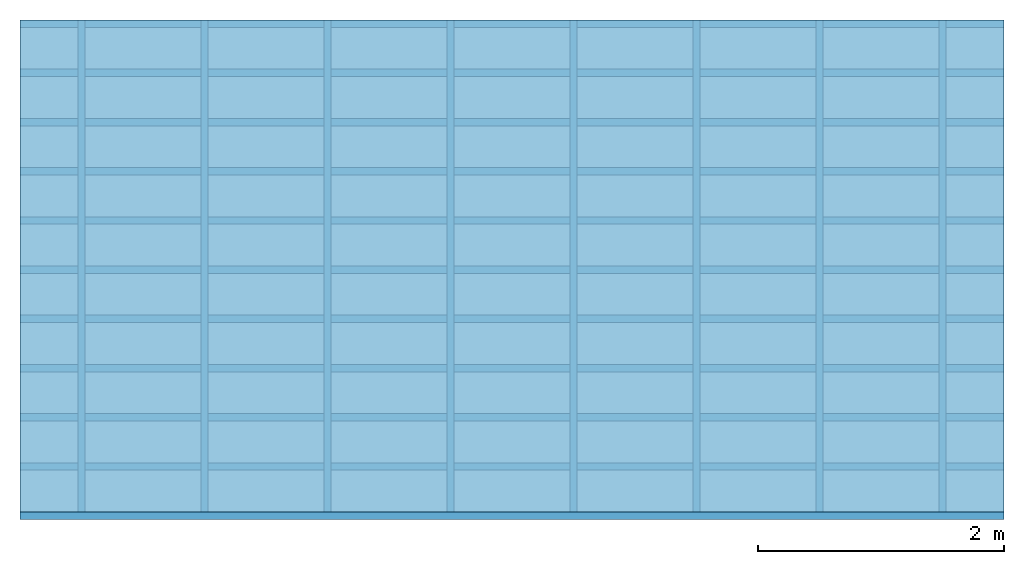
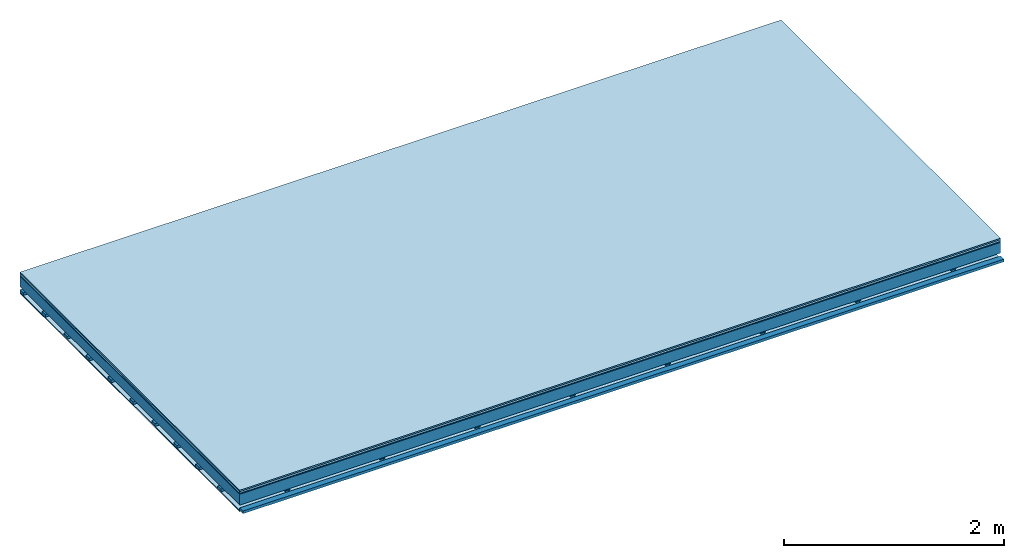
# One storey: 5 plates, 3 members, 1 element without a shape of its own.
"""IFC4 building model written with IfcOpenShell, lengths in metres."""

import ifcopenshell
import ifcopenshell.guid

model = None  # the IFC model being written
_history = None  # IfcOwnerHistory: only IFC2X3 demands one
_inside = {}  # id of a spatial element -> (the spatial element, [elements in it])
_under = {}  # id of a project, library or spatial element -> (it, [spatial elements below it])
_declared = {}  # id of a project -> (the project, [libraries it declares])
_typed = {}  # id of a type object -> (the type object, [elements of that type])
_made_of = {}  # id of a material, layer set ... -> (it, [elements and type objects made of it])


def new_model(schema):
    """Start an empty IFC model of exactly this schema.

    Asked for "IFC4X3", IfcOpenShell would pick the latest addendum, in which some entities
    have other attributes; the version numbers below select the first issue.
    IFC2X3 requires an IfcOwnerHistory on every rooted entity: one is made here for all.
    """
    global model, _history
    if schema == "IFC4X3":
        model = ifcopenshell.file(schema_version=(4, 3, 0, 0))
    else:
        model = ifcopenshell.file(schema=schema)
    _inside.clear()
    _under.clear()
    _declared.clear()
    _typed.clear()
    _made_of.clear()
    _history = None
    if model.schema == "IFC2X3":
        org = make("IfcOrganization", Name="unknown")
        user = make(
            "IfcPersonAndOrganization",
            ThePerson=make("IfcPerson", FamilyName="unknown"),
            TheOrganization=org,
        )
        app = make(
            "IfcApplication",
            ApplicationDeveloper=org,
            Version="unknown",
            ApplicationFullName="unknown",
            ApplicationIdentifier="unknown",
        )
        _history = make(
            "IfcOwnerHistory",
            OwningUser=user,
            OwningApplication=app,
            ChangeAction="ADDED",
            CreationDate=0,
        )
    return model


def make(cls, **values):
    """One entity of the class cls with the attributes given. An attribute that is None is left unset."""
    return model.create_entity(
        cls, **{name: value for name, value in values.items() if value is not None}
    )


def rooted(cls, **values):
    """An entity with a GlobalId (a new one), such as an element, a storey or a relation."""
    return make(cls, GlobalId=ifcopenshell.guid.new(), OwnerHistory=_history, **values)


def si_unit(unit_type, name, prefix=None):
    """IfcSIUnit, for example si_unit("LENGTHUNIT", "METRE", prefix="MILLI")."""
    return make("IfcSIUnit", UnitType=unit_type, Prefix=prefix, Name=name)


def derived_unit(unit_type, elements):
    """IfcDerivedUnit: a product of units, each with its exponent."""
    return make(
        "IfcDerivedUnit",
        Elements=[
            make("IfcDerivedUnitElement", Unit=unit, Exponent=power)
            for unit, power in elements
        ],
        UnitType=unit_type,
    )


def assignment(units):
    """IfcUnitAssignment: the units of a project."""
    return None if units is None else make("IfcUnitAssignment", Units=units)


def point(xyz):
    """IfcCartesianPoint."""
    return None if xyz is None else make("IfcCartesianPoint", Coordinates=xyz)


def direction(xyz):
    """IfcDirection."""
    return None if xyz is None else make("IfcDirection", DirectionRatios=xyz)


def frame(location, z_axis=None, x_axis=None):
    """IfcAxis2Placement3D, a coordinate frame: its origin and axes. An axis left out is left unset."""
    return make(
        "IfcAxis2Placement3D",
        Location=point(location),
        Axis=direction(z_axis),
        RefDirection=direction(x_axis),
    )


def frame_2d(location, x_axis=None):
    """IfcAxis2Placement2D, a coordinate frame in the plane: its origin and x axis."""
    return make(
        "IfcAxis2Placement2D", Location=point(location), RefDirection=direction(x_axis)
    )


def origin():
    """The frame at (0, 0, 0) with its axes left unset."""
    return frame((0.0, 0.0, 0.0))


def origin_with_axes():
    """The frame at (0, 0, 0) with the z axis (0, 0, 1) and the x axis (1, 0, 0) written out."""
    return frame((0.0, 0.0, 0.0), z_axis=(0.0, 0.0, 1.0), x_axis=(1.0, 0.0, 0.0))


def place(relative_to, where):
    """IfcLocalPlacement: puts the frame where relative to a parent placement (None: the world)."""
    return make(
        "IfcLocalPlacement", PlacementRelTo=relative_to, RelativePlacement=where
    )


def context(
    kind, dimensions, precision=None, world=None, true_north=None, identifier=None
):
    """IfcGeometricRepresentationContext, for example the 3D "Model" context."""
    return make(
        "IfcGeometricRepresentationContext",
        ContextIdentifier=identifier,
        ContextType=kind,
        CoordinateSpaceDimension=dimensions,
        Precision=precision,
        WorldCoordinateSystem=world,
        TrueNorth=true_north,
    )


def project(units=None, contexts=None):
    """IfcProject with its units and contexts."""
    return rooted(
        "IfcProject",
        Name="project",
        RepresentationContexts=contexts,
        UnitsInContext=assignment(units),
    )


def spatial(cls, under=None, at=None, **own):
    """A site, building, storey or space (cls), placed at a placement, below another one or the project."""
    s = rooted(cls, ObjectPlacement=at, **own)
    if under is not None:
        _under.setdefault(under.id(), (under, []))[1].append(s)
    return s


def polyline(points):
    """IfcPolyline through the points."""
    return make("IfcPolyline", Points=[point(p) for p in points])


def profile(cls, at=None, kind="AREA", **sizes):
    """A parametric profile (cls). Its sizes go by their IFC names, for example OverallWidth=200.0."""
    return make(cls, ProfileType=kind, Position=at, **sizes)


def rectangle(**sizes):
    """IfcRectangleProfileDef."""
    return profile("IfcRectangleProfileDef", **sizes)


def outline(outer, holes=None, kind="AREA"):
    """IfcArbitraryClosedProfileDef: a profile drawn as a closed curve; with holes, ...WithVoids."""
    if holes is None:
        return make("IfcArbitraryClosedProfileDef", ProfileType=kind, OuterCurve=outer)
    return make(
        "IfcArbitraryProfileDefWithVoids",
        ProfileType=kind,
        OuterCurve=outer,
        InnerCurves=holes,
    )


def extrude(swept, where, along, depth):
    """IfcExtrudedAreaSolid: the profile swept, set in the frame where, extruded along a direction by depth."""
    return make(
        "IfcExtrudedAreaSolid",
        SweptArea=swept,
        Position=where,
        ExtrudedDirection=direction(along),
        Depth=depth,
    )


def shape(context_of_items, identifier, shape_type, items):
    """IfcShapeRepresentation: the items that make up one representation, for example the "Body"."""
    return make(
        "IfcShapeRepresentation",
        ContextOfItems=context_of_items,
        RepresentationIdentifier=identifier,
        RepresentationType=shape_type,
        Items=items,
    )


def material(Name=None, Category=None):
    """IfcMaterial."""
    return make("IfcMaterial", Name=Name, Category=Category)


def layer(
    of_material, thickness, ventilated=None, Name=None, Category=None, Priority=None
):
    """IfcMaterialLayer: one layer of a wall or slab, of a material (None: an air gap)."""
    return make(
        "IfcMaterialLayer",
        Material=of_material,
        LayerThickness=thickness,
        IsVentilated=ventilated,
        Name=Name,
        Category=Category,
        Priority=Priority,
    )


def layer_set(layers, Name=None):
    """IfcMaterialLayerSet."""
    return make("IfcMaterialLayerSet", MaterialLayers=layers, LayerSetName=Name)


def made_of(thing, what):
    """Note that an element or type object is made of a material, layer set ...; save() writes the relation."""
    if what is not None:
        _made_of.setdefault(what.id(), (what, []))[1].append(thing)
    return thing


def type_object(cls, material=None, **own):
    """A type object (cls), such as IfcWallType, which elements share."""
    return made_of(rooted(cls, **own), material)


def element(
    cls,
    number,
    at=None,
    inside=None,
    cuts=None,
    type_object=None,
    material=None,
    context=None,
    identifier="Body",
    shape_type=None,
    held_by="IfcProductDefinitionShape",
    body=None,
    shapes=None,
    **own,
):
    """One element of the class cls, such as IfcWall. Its Tag is "e" and its number.

    at: its placement. inside: the storey or other place that contains it. cuts: it is an
    opening in that element (IfcRelVoidsElement). A single representation is given by context,
    identifier, shape_type and body (its items); several are given by shapes. held_by: the class
    of the entity that holds the representations. save() writes the other relations.
    """
    e = rooted(cls, Tag="e%d" % number, ObjectPlacement=at, **own)
    if body is not None:
        shapes = [shape(context, identifier, shape_type, body)]
    if shapes is not None:
        e.Representation = make(held_by, Representations=shapes)
    if inside is not None:
        _inside.setdefault(inside.id(), (inside, []))[1].append(e)
    if cuts is not None:
        rooted(
            "IfcRelVoidsElement", RelatingBuildingElement=cuts, RelatedOpeningElement=e
        )
    if type_object is not None:
        _typed.setdefault(type_object.id(), (type_object, []))[1].append(e)
    return made_of(e, material)


def aggregate(whole, parts):
    """IfcRelAggregates: a whole, such as a stair, and the parts it consists of."""
    return rooted("IfcRelAggregates", RelatingObject=whole, RelatedObjects=parts)


def save(model, path):
    """Write the relations noted so far, then the file.

    IfcRelAggregates (storeys below a building ...), IfcRelContainedInSpatialStructure (elements
    in a storey), IfcRelDefinesByType, IfcRelAssociatesMaterial and IfcRelDeclares: one each for
    every whole, place, type object, material and project.
    """
    for whole, parts in _under.values():
        aggregate(whole, parts)
    for where, things in _inside.values():
        rooted(
            "IfcRelContainedInSpatialStructure",
            RelatedElements=things,
            RelatingStructure=where,
        )
    for kind, things in _typed.values():
        rooted("IfcRelDefinesByType", RelatedObjects=things, RelatingType=kind)
    for what, things in _made_of.values():
        rooted("IfcRelAssociatesMaterial", RelatedObjects=things, RelatingMaterial=what)
    for by, libraries in _declared.values():
        rooted("IfcRelDeclares", RelatingContext=by, RelatedDefinitions=libraries)
    model.write(path)


model = new_model("IFC4")

# Units and contexts
plan_context = context("Plan", 3, precision=1e-05, world=origin(), true_north=direction((0.0, 1.0)))
model_context = context("Model", 3, precision=1e-05, world=origin(), true_north=direction((0.0, 1.0)))
ifc_project = project(units=[si_unit("LENGTHUNIT", "METRE"), derived_unit("SOUNDPRESSUREUNIT", [(si_unit("PRESSUREUNIT", "PASCAL", prefix="MICRO"), 0)]), si_unit("ENERGYUNIT", "JOULE", prefix="MEGA"), si_unit("MASSUNIT", "GRAM", prefix="KILO"), derived_unit("THERMALTRANSMITTANCEUNIT", [(si_unit("POWERUNIT", "WATT"), 1), (si_unit("AREAUNIT", "SQUARE_METRE"), -1), (si_unit("THERMODYNAMICTEMPERATUREUNIT", "KELVIN"), -1)]), derived_unit("AREADENSITYUNIT", [(si_unit("MASSUNIT", "GRAM", prefix="KILO"), 1), (si_unit("AREAUNIT", "SQUARE_METRE"), -1)]), derived_unit("USERDEFINED", [(si_unit("ENERGYUNIT", "JOULE", prefix="MEGA"), 1), (si_unit("AREAUNIT", "SQUARE_METRE"), -1)])], contexts=[plan_context, model_context])

# Site, building, storey
site = spatial("IfcSite", under=ifc_project)
building_placement = place(None, origin())
building = spatial("IfcBuilding", under=site, at=building_placement)
storey_placement = place(building_placement, origin())
storey = spatial("IfcBuildingStorey", under=building, at=storey_placement)

# Slab, members, plates
ifc_material_1 = material(Category="11.013")
ifc_layer_1 = layer(ifc_material_1, 0.015, Name="Flooring")
ifc_material_2 = material(Category="03.007")
ifc_layer_2 = layer(ifc_material_2, 0.02, Name="On-material")
ifc_material_3 = material(Name="Wood fiber generic product", Category="10.009")
ifc_layer_3 = layer(ifc_material_3, 0.01, Name="Impact sound insulation")
ifc_material_4 = material(Name="no composite action")
ifc_layer_4 = layer(ifc_material_4, 0.0, Name="Bond")
ifc_layer_5 = layer(None, 0.12, Name="Supporting structure")
ifc_layer_6 = layer(ifc_material_4, 0.0, Name="Bond")
ifc_layer_7 = layer(None, 0.03, Name="Coupling")
ifc_layer_8 = layer(None, 0.03, Name="Battens / profiles")
ifc_material_5 = material(Name="Plasterboard type A", Category="03.008")
ifc_layer_9 = layer(ifc_material_5, 0.0125, Name="Ceiling covering 1st layer")
ifc_material_6 = material(Category="04.001")
ifc_layer_10 = layer(ifc_material_6, 0.003, Name="Surface / treatment")
ifc_layer_set = layer_set([ifc_layer_1, ifc_layer_2, ifc_layer_3, ifc_layer_4, ifc_layer_5, ifc_layer_6, ifc_layer_7, ifc_layer_8, ifc_layer_9, ifc_layer_10])
slab_type = type_object("IfcSlabType", Name="A2096", PredefinedType="NOTDEFINED", material=ifc_layer_set)
slab_placement = place(None, frame((0.0, 0.0, 0.0), z_axis=(0.0, 0.0, -1.0), x_axis=(1.0, 0.0, 0.0)))
slab = element("IfcSlab", 1, at=slab_placement, inside=storey, type_object=slab_type, material=ifc_layer_set, Name="Slab #1")
ifc_material_7 = material(Name="Solid timber panel")
member_1_placement = place(slab_placement, origin())
member_1 = element("IfcMember", 2, at=member_1_placement, material=ifc_material_7, Name="Supporting structure", context=plan_context, shape_type="SweptSolid", body=[
    extrude(rectangle(XDim=1.0, YDim=0.12, at=frame_2d((0.5, 0.06), x_axis=(1.0, 0.0))), frame((0.0, 4.0, 0.045), z_axis=(0.0, -1.0, 0.0), x_axis=(1.0, 0.0, 0.0)), (0.0, 0.0, 1.0), 4.0),
    extrude(rectangle(XDim=1.0, YDim=0.12, at=frame_2d((0.5, 0.06), x_axis=(1.0, 0.0))), frame((1.0, 4.0, 0.045), z_axis=(0.0, -1.0, 0.0), x_axis=(1.0, 0.0, 0.0)), (0.0, 0.0, 1.0), 4.0),
    extrude(rectangle(XDim=1.0, YDim=0.12, at=frame_2d((0.5, 0.06), x_axis=(1.0, 0.0))), frame((2.0, 4.0, 0.045), z_axis=(0.0, -1.0, 0.0), x_axis=(1.0, 0.0, 0.0)), (0.0, 0.0, 1.0), 4.0),
    extrude(rectangle(XDim=1.0, YDim=0.12, at=frame_2d((0.5, 0.06), x_axis=(1.0, 0.0))), frame((3.0, 4.0, 0.045), z_axis=(0.0, -1.0, 0.0), x_axis=(1.0, 0.0, 0.0)), (0.0, 0.0, 1.0), 4.0),
    extrude(rectangle(XDim=1.0, YDim=0.12, at=frame_2d((0.5, 0.06), x_axis=(1.0, 0.0))), frame((4.0, 4.0, 0.045), z_axis=(0.0, -1.0, 0.0), x_axis=(1.0, 0.0, 0.0)), (0.0, 0.0, 1.0), 4.0),
    extrude(rectangle(XDim=1.0, YDim=0.12, at=frame_2d((0.5, 0.06), x_axis=(1.0, 0.0))), frame((5.0, 4.0, 0.045), z_axis=(0.0, -1.0, 0.0), x_axis=(1.0, 0.0, 0.0)), (0.0, 0.0, 1.0), 4.0),
    extrude(rectangle(XDim=1.0, YDim=0.12, at=frame_2d((0.5, 0.06), x_axis=(1.0, 0.0))), frame((6.0, 4.0, 0.045), z_axis=(0.0, -1.0, 0.0), x_axis=(1.0, 0.0, 0.0)), (0.0, 0.0, 1.0), 4.0),
    extrude(rectangle(XDim=1.0, YDim=0.12, at=frame_2d((0.5, 0.06), x_axis=(1.0, 0.0))), frame((7.0, 4.0, 0.045), z_axis=(0.0, -1.0, 0.0), x_axis=(1.0, 0.0, 0.0)), (0.0, 0.0, 1.0), 4.0),
])
ifc_material_8 = material()
member_2_placement = place(slab_placement, origin())
member_2 = element("IfcMember", 3, at=member_2_placement, material=ifc_material_8, Name="Coupling", context=plan_context, shape_type="SweptSolid", body=[
    extrude(outline(polyline([(0.0, 0.0), (0.06, 0.0), (0.04, 0.02), (0.02, 0.02), (0.0, 0.0)])), frame((0.47, 4.0, 0.175), z_axis=(0.0, -1.0, 0.0), x_axis=(1.0, 0.0, 0.0)), (0.0, 0.0, 1.0), 4.0),
    extrude(outline(polyline([(0.0, 0.0), (0.06, 0.0), (0.04, 0.02), (0.02, 0.02), (0.0, 0.0)])), frame((1.47, 4.0, 0.175), z_axis=(0.0, -1.0, 0.0), x_axis=(1.0, 0.0, 0.0)), (0.0, 0.0, 1.0), 4.0),
    extrude(outline(polyline([(0.0, 0.0), (0.06, 0.0), (0.04, 0.02), (0.02, 0.02), (0.0, 0.0)])), frame((2.47, 4.0, 0.175), z_axis=(0.0, -1.0, 0.0), x_axis=(1.0, 0.0, 0.0)), (0.0, 0.0, 1.0), 4.0),
    extrude(outline(polyline([(0.0, 0.0), (0.06, 0.0), (0.04, 0.02), (0.02, 0.02), (0.0, 0.0)])), frame((3.47, 4.0, 0.175), z_axis=(0.0, -1.0, 0.0), x_axis=(1.0, 0.0, 0.0)), (0.0, 0.0, 1.0), 4.0),
    extrude(outline(polyline([(0.0, 0.0), (0.06, 0.0), (0.04, 0.02), (0.02, 0.02), (0.0, 0.0)])), frame((4.47, 4.0, 0.175), z_axis=(0.0, -1.0, 0.0), x_axis=(1.0, 0.0, 0.0)), (0.0, 0.0, 1.0), 4.0),
    extrude(outline(polyline([(0.0, 0.0), (0.06, 0.0), (0.04, 0.02), (0.02, 0.02), (0.0, 0.0)])), frame((5.47, 4.0, 0.175), z_axis=(0.0, -1.0, 0.0), x_axis=(1.0, 0.0, 0.0)), (0.0, 0.0, 1.0), 4.0),
    extrude(outline(polyline([(0.0, 0.0), (0.06, 0.0), (0.04, 0.02), (0.02, 0.02), (0.0, 0.0)])), frame((6.47, 4.0, 0.175), z_axis=(0.0, -1.0, 0.0), x_axis=(1.0, 0.0, 0.0)), (0.0, 0.0, 1.0), 4.0),
    extrude(outline(polyline([(0.0, 0.0), (0.06, 0.0), (0.04, 0.02), (0.02, 0.02), (0.0, 0.0)])), frame((7.47, 4.0, 0.175), z_axis=(0.0, -1.0, 0.0), x_axis=(1.0, 0.0, 0.0)), (0.0, 0.0, 1.0), 4.0),
])
member_3_placement = place(slab_placement, origin())
member_3 = element("IfcMember", 4, at=member_3_placement, material=ifc_material_8, Name="Battens / profiles", context=plan_context, shape_type="SweptSolid", body=[
    extrude(rectangle(XDim=0.06, YDim=0.03, at=frame_2d((0.03, 0.015), x_axis=(1.0, 0.0))), frame((0.0, 0.0, 0.195), z_axis=(1.0, 0.0, 0.0), x_axis=(0.0, 1.0, 0.0)), (0.0, 0.0, 1.0), 8.0),
    extrude(rectangle(XDim=0.06, YDim=0.03, at=frame_2d((0.03, 0.015), x_axis=(1.0, 0.0))), frame((0.0, 0.4, 0.195), z_axis=(1.0, 0.0, 0.0), x_axis=(0.0, 1.0, 0.0)), (0.0, 0.0, 1.0), 8.0),
    extrude(rectangle(XDim=0.06, YDim=0.03, at=frame_2d((0.03, 0.015), x_axis=(1.0, 0.0))), frame((0.0, 0.8, 0.195), z_axis=(1.0, 0.0, 0.0), x_axis=(0.0, 1.0, 0.0)), (0.0, 0.0, 1.0), 8.0),
    extrude(rectangle(XDim=0.06, YDim=0.03, at=frame_2d((0.03, 0.015), x_axis=(1.0, 0.0))), frame((0.0, 1.2, 0.195), z_axis=(1.0, 0.0, 0.0), x_axis=(0.0, 1.0, 0.0)), (0.0, 0.0, 1.0), 8.0),
    extrude(rectangle(XDim=0.06, YDim=0.03, at=frame_2d((0.03, 0.015), x_axis=(1.0, 0.0))), frame((0.0, 1.6, 0.195), z_axis=(1.0, 0.0, 0.0), x_axis=(0.0, 1.0, 0.0)), (0.0, 0.0, 1.0), 8.0),
    extrude(rectangle(XDim=0.06, YDim=0.03, at=frame_2d((0.03, 0.015), x_axis=(1.0, 0.0))), frame((0.0, 2.0, 0.195), z_axis=(1.0, 0.0, 0.0), x_axis=(0.0, 1.0, 0.0)), (0.0, 0.0, 1.0), 8.0),
    extrude(rectangle(XDim=0.06, YDim=0.03, at=frame_2d((0.03, 0.015), x_axis=(1.0, 0.0))), frame((0.0, 2.4, 0.195), z_axis=(1.0, 0.0, 0.0), x_axis=(0.0, 1.0, 0.0)), (0.0, 0.0, 1.0), 8.0),
    extrude(rectangle(XDim=0.06, YDim=0.03, at=frame_2d((0.03, 0.015), x_axis=(1.0, 0.0))), frame((0.0, 2.8, 0.195), z_axis=(1.0, 0.0, 0.0), x_axis=(0.0, 1.0, 0.0)), (0.0, 0.0, 1.0), 8.0),
    extrude(rectangle(XDim=0.06, YDim=0.03, at=frame_2d((0.03, 0.015), x_axis=(1.0, 0.0))), frame((0.0, 3.2, 0.195), z_axis=(1.0, 0.0, 0.0), x_axis=(0.0, 1.0, 0.0)), (0.0, 0.0, 1.0), 8.0),
    extrude(rectangle(XDim=0.06, YDim=0.03, at=frame_2d((0.03, 0.015), x_axis=(1.0, 0.0))), frame((0.0, 3.6, 0.195), z_axis=(1.0, 0.0, 0.0), x_axis=(0.0, 1.0, 0.0)), (0.0, 0.0, 1.0), 8.0),
    extrude(rectangle(XDim=0.06, YDim=0.03, at=frame_2d((0.03, 0.015), x_axis=(1.0, 0.0))), frame((0.0, 4.0, 0.195), z_axis=(1.0, 0.0, 0.0), x_axis=(0.0, 1.0, 0.0)), (0.0, 0.0, 1.0), 8.0),
])
plate_1_placement = place(slab_placement, origin())
plate_1 = element("IfcPlate", 5, at=plate_1_placement, material=ifc_material_1, Name="Flooring", context=plan_context, shape_type="SweptSolid", body=[
    extrude(rectangle(XDim=8.0, YDim=4.0, at=frame_2d((4.0, 2.0), x_axis=(1.0, 0.0))), origin_with_axes(), (0.0, 0.0, 1.0), 0.015),
])
plate_2_placement = place(slab_placement, origin())
plate_2 = element("IfcPlate", 6, at=plate_2_placement, material=ifc_material_2, Name="On-material", context=plan_context, shape_type="SweptSolid", body=[
    extrude(rectangle(XDim=8.0, YDim=4.0, at=frame_2d((4.0, 2.0), x_axis=(1.0, 0.0))), frame((0.0, 0.0, 0.015), z_axis=(0.0, 0.0, 1.0), x_axis=(1.0, 0.0, 0.0)), (0.0, 0.0, 1.0), 0.02),
])
plate_3_placement = place(slab_placement, origin())
plate_3 = element("IfcPlate", 7, at=plate_3_placement, material=ifc_material_3, Name="Impact sound insulation", context=plan_context, shape_type="SweptSolid", body=[
    extrude(rectangle(XDim=8.0, YDim=4.0, at=frame_2d((4.0, 2.0), x_axis=(1.0, 0.0))), frame((0.0, 0.0, 0.035), z_axis=(0.0, 0.0, 1.0), x_axis=(1.0, 0.0, 0.0)), (0.0, 0.0, 1.0), 0.01),
])
plate_4_placement = place(slab_placement, origin())
plate_4 = element("IfcPlate", 8, at=plate_4_placement, material=ifc_material_5, Name="Ceiling covering 1st layer", context=plan_context, shape_type="SweptSolid", body=[
    extrude(rectangle(XDim=8.0, YDim=4.0, at=frame_2d((4.0, 2.0), x_axis=(1.0, 0.0))), frame((0.0, 0.0, 0.225), z_axis=(0.0, 0.0, 1.0), x_axis=(1.0, 0.0, 0.0)), (0.0, 0.0, 1.0), 0.0125),
])
plate_5_placement = place(slab_placement, origin())
plate_5 = element("IfcPlate", 9, at=plate_5_placement, material=ifc_material_6, Name="Surface / treatment", context=plan_context, shape_type="SweptSolid", body=[
    extrude(rectangle(XDim=8.0, YDim=4.0, at=frame_2d((4.0, 2.0), x_axis=(1.0, 0.0))), frame((0.0, 0.0, 0.2375), z_axis=(0.0, 0.0, 1.0), x_axis=(1.0, 0.0, 0.0)), (0.0, 0.0, 1.0), 0.003),
])
aggregate(slab, [plate_1, plate_2, plate_3, member_1, member_2, member_3, plate_4, plate_5])

save(model, "model.ifc")
